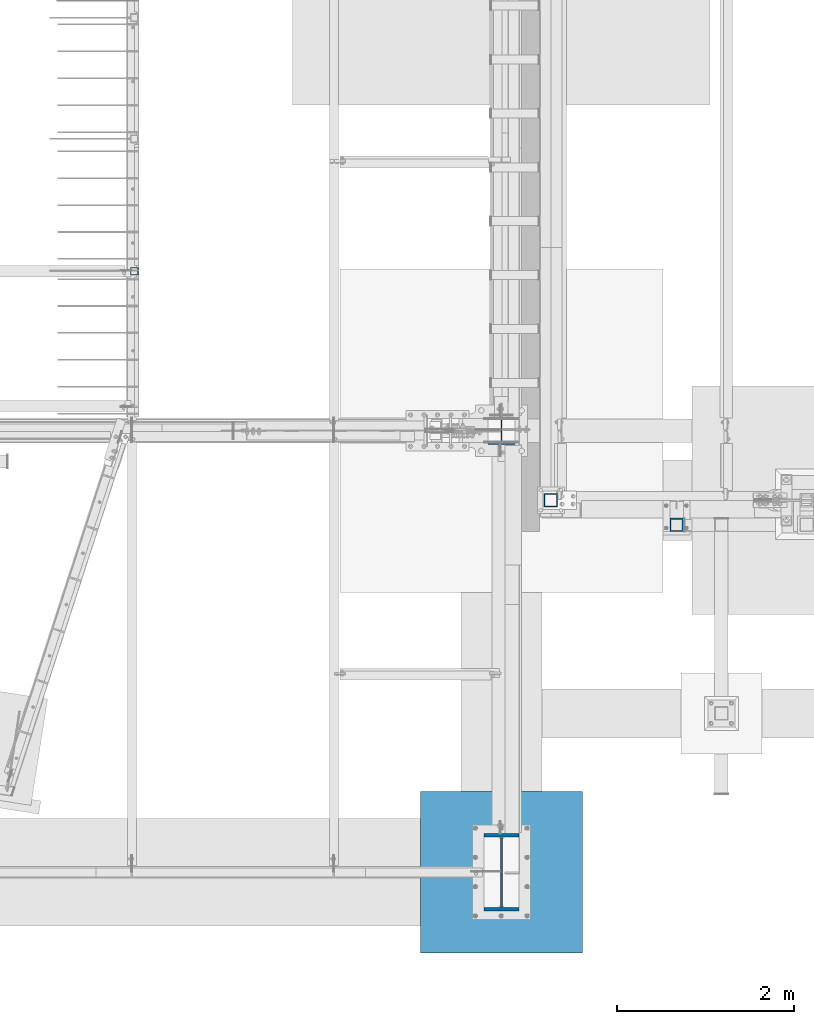
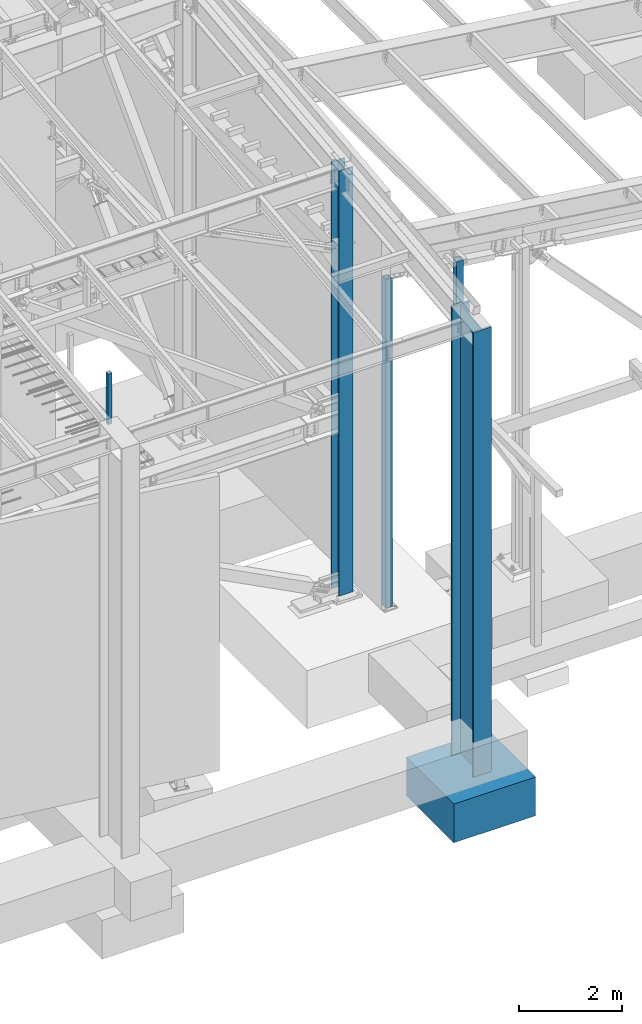
# One storey, part 354 of 1179: 6 columns, 6 elements without a shape of their own.
"""IFC2X3 building model written with IfcOpenShell, lengths in millimetres."""

from ifc_helpers import new_model, si_unit, frame, origin_with_axes, place, context, subcontext, project, spatial, faceted_brep, material, type_object, element, aggregate, save


model = new_model("IFC2X3")

# Units and contexts
model_context = context("Model", 3, precision=1e-05, world=origin_with_axes())
body_context = subcontext(model_context, "Body", "Model", "MODEL_VIEW")
ifc_project = project(units=[si_unit("LENGTHUNIT", "METRE", prefix="MILLI"), si_unit("AREAUNIT", "SQUARE_METRE"), si_unit("VOLUMEUNIT", "CUBIC_METRE"), si_unit("MASSUNIT", "GRAM", prefix="KILO"), si_unit("TIMEUNIT", "SECOND"), si_unit("PLANEANGLEUNIT", "RADIAN"), si_unit("SOLIDANGLEUNIT", "STERADIAN"), si_unit("THERMODYNAMICTEMPERATUREUNIT", "DEGREE_CELSIUS"), si_unit("LUMINOUSINTENSITYUNIT", "LUMEN")], contexts=[model_context])

# Site, building, storey
site_placement = place(None, origin_with_axes())
site = spatial("IfcSite", under=ifc_project, at=site_placement, CompositionType="ELEMENT")
building_placement = place(site_placement, origin_with_axes())
building = spatial("IfcBuilding", under=site, at=building_placement, Name="Undefined", CompositionType="ELEMENT")
storey_placement = place(building_placement, origin_with_axes())
storey = spatial("IfcBuildingStorey", under=building, at=storey_placement, Name="Undefined", CompositionType="ELEMENT", Elevation=0.0)

# Assembly, column
assembly_1_placement = place(storey_placement, origin_with_axes())
assembly_1 = element("IfcElementAssembly", 1, at=assembly_1_placement, inside=storey, Name="COLUMN", AssemblyPlace="NOTDEFINED", PredefinedType="RIGID_FRAME")
ifc_material_1 = material()
column_type_1 = type_object("IfcColumnType", Name="HSS6X6X3/8", PredefinedType="NOTDEFINED")
column_1_placement = place(assembly_1_placement, frame((24866.6, 4648.2, -355.6), z_axis=(0.0, 1.0, 0.0), x_axis=(0.0, 0.0, 1.0)))
column_1 = element("IfcColumn", 2, at=column_1_placement, type_object=column_type_1, material=ifc_material_1, Name="COLUMN", ObjectType="HSS6X6X3/8", context=body_context, shape_type="Brep", body=[
    faceted_brep([(76.2000000000008, 66.675000000112, -66.6749999999902), (76.2000000000008, -66.6750000001084, -66.6750000000175), (7835.60224230485, -66.6749999999993, -66.6750000000002), (7817.5963138271, 66.6749999999993, -66.6750000000002), (76.2000000000008, -66.6750000001011, 66.674999999992), (7835.60224230485, -66.6749999999993, 66.6750000000002), (76.2000000000008, 66.6750000001193, 66.6750000000193), (7817.5963138271, 66.6749999999993, 66.6750000000002), (76.2000000000008, 76.2000000001281, -76.1999999999898), (76.2000000000008, 76.2000000001317, 76.2000000000216), (7816.31017607869, 76.2000000000007, 76.1999999999998), (7816.31017607869, 76.2000000000007, -76.1999999999998), (76.2000000000008, -76.2000000001171, 76.1999999999916), (7836.88838005326, -76.2000000000007, 76.1999999999998), (76.2000000000008, -76.2000000001208, -76.2000000000198), (7836.88838005326, -76.2000000000007, -76.1999999999998)], [[[0, 1, 2, 3]], [[1, 4, 5, 2]], [[4, 6, 7, 5]], [[6, 0, 3, 7]], [[8, 9, 10, 11]], [[9, 12, 13, 10]], [[12, 14, 15, 13]], [[14, 8, 11, 15]], [[13, 15, 11, 10], [5, 7, 3, 2]], [[14, 12, 9, 8], [6, 4, 1, 0]]]),
])
aggregate(assembly_1, [column_1])

assembly_2_placement = place(storey_placement, origin_with_axes())
assembly_2 = element("IfcElementAssembly", 3, at=assembly_2_placement, inside=storey, Name="COLUMN", AssemblyPlace="NOTDEFINED", PredefinedType="RIGID_FRAME")
column_type_2 = type_object("IfcColumnType", Name="HSS3-1/2X3-1/2X5/16", PredefinedType="NOTDEFINED")
column_2_placement = place(assembly_2_placement, frame((20154.9, 7239.0, 4102.1), z_axis=(0.0, 1.0, 0.0), x_axis=(0.0, 0.0, 1.0)))
column_2 = element("IfcColumn", 4, at=column_2_placement, type_object=column_type_2, material=ifc_material_1, Name="COLUMN", ObjectType="HSS3-1/2X3-1/2X5/16", context=body_context, shape_type="Brep", body=[
    faceted_brep([(0.0, 36.5125000000007, -36.5125000000007), (0.0, -36.5125000000007, -36.5125000000007), (1195.387, -36.5125000000007, -36.5125000000007), (1195.387, 36.5125000000007, -36.5125000000007), (0.0, -36.5125000000007, 36.5125000000007), (1195.387, -36.5125000000007, 36.5125000000007), (0.0, 36.5125000000007, 36.5125000000007), (1195.387, 36.5125000000007, 36.5125000000007), (0.0, 44.4500000000007, -44.4499999999998), (0.0, 44.4500000000007, 44.4500000000007), (1195.387, 44.4500000000007, 44.4500000000007), (1195.387, 44.4500000000007, -44.4500000000007), (0.0, -44.4500000000007, 44.4500000000007), (1195.387, -44.4500000000007, 44.4500000000007), (0.0, -44.4500000000007, -44.4500000000007), (1195.387, -44.4500000000007, -44.4500000000007)], [[[0, 1, 2, 3]], [[1, 4, 5, 2]], [[4, 6, 7, 5]], [[6, 0, 3, 7]], [[8, 9, 10, 11]], [[9, 12, 13, 10]], [[12, 14, 15, 13]], [[14, 8, 11, 15]], [[13, 15, 11, 10], [5, 7, 3, 2]], [[14, 12, 9, 8], [6, 4, 1, 0]]]),
])
aggregate(assembly_2, [column_2])

assembly_3_placement = place(storey_placement, origin_with_axes())
assembly_3 = element("IfcElementAssembly", 5, at=assembly_3_placement, inside=storey, Name="FOOTING", AssemblyPlace="NOTDEFINED", PredefinedType="REINFORCEMENT_UNIT")
ifc_material_2 = material(Name="CONCRETE/3000")
column_type_3 = type_object("IfcColumnType", PredefinedType="NOTDEFINED")
column_3_placement = place(assembly_3_placement, frame((24307.8, 438.15, -2260.6), z_axis=(-1.0, 0.0, 0.0), x_axis=(0.0, 0.0, 1.0)))
column_3 = element("IfcColumn", 6, at=column_3_placement, type_object=column_type_3, material=ifc_material_2, Name="FOOTING", context=body_context, shape_type="Brep", body=[
    faceted_brep([(0.0, 914.400000000001, -914.400000000001), (0.0, 914.400000000001, 914.400000000001), (914.4, 914.4, 914.400000000001), (914.4, 914.4, -914.400000000001), (0.0, -914.400000000001, 914.400000000001), (914.4, -914.4, 914.400000000001), (0.0, -914.400000000001, -914.400000000001), (914.4, -914.4, -914.400000000001)], [[[0, 1, 2, 3]], [[1, 4, 5, 2]], [[4, 6, 7, 5]], [[6, 0, 3, 7]], [[5, 7, 3, 2]], [[6, 4, 1, 0]]]),
])
aggregate(assembly_3, [column_3])

assembly_4_placement = place(storey_placement, origin_with_axes())
assembly_4 = element("IfcElementAssembly", 7, at=assembly_4_placement, inside=storey, Name="COLUMN", AssemblyPlace="NOTDEFINED", PredefinedType="RIGID_FRAME")
column_type_4 = type_object("IfcColumnType", Name="HSS6X6X1/2", PredefinedType="NOTDEFINED")
column_4_placement = place(assembly_4_placement, frame((26289.0, 4368.8, -431.8), z_axis=(0.0, 1.0, 0.0), x_axis=(0.0, 0.0, 1.0)))
column_4 = element("IfcColumn", 8, at=column_4_placement, type_object=column_type_4, material=ifc_material_1, Name="COLUMN", ObjectType="HSS6X6X1/2", context=body_context, shape_type="Brep", body=[
    faceted_brep([(57.15, 63.5, -63.5), (57.15, -63.5, -63.5), (7997.7194715117, -63.5, -63.5), (7997.7194715117, 63.5, -63.5), (57.15, -63.5, 63.5), (7997.7194715117, -63.5, 63.5), (57.15, 63.5, 63.5), (7997.7194715117, 63.5, 63.5), (57.15, 76.1999999999789, -76.1999999999953), (57.15, 76.2000000000112, 76.1999999999979), (7997.7194715117, 76.2000000000007, 76.1999999999998), (7997.7194715117, 76.2000000000007, -76.1999999999998), (57.15, -76.1999999999789, 76.1999999999952), (7997.7194715117, -76.2000000000007, 76.1999999999998), (57.15, -76.2000000000116, -76.199999999998), (7997.7194715117, -76.2000000000007, -76.1999999999998)], [[[0, 1, 2, 3]], [[1, 4, 5, 2]], [[4, 6, 7, 5]], [[6, 0, 3, 7]], [[8, 9, 10, 11]], [[9, 12, 13, 10]], [[12, 14, 15, 13]], [[14, 8, 11, 15]], [[13, 15, 11, 10], [5, 7, 3, 2]], [[14, 12, 9, 8], [6, 4, 1, 0]]]),
])
aggregate(assembly_4, [column_4])

assembly_5_placement = place(storey_placement, origin_with_axes())
assembly_5 = element("IfcElementAssembly", 9, at=assembly_5_placement, inside=storey, Name="COLUMN", AssemblyPlace="NOTDEFINED", PredefinedType="RIGID_FRAME")
ifc_material_3 = material(Name="STEEL/A992")
column_type_5 = type_object("IfcColumnType", Name="W33X263", PredefinedType="NOTDEFINED")
column_5_placement = place(assembly_5_placement, frame((24307.8, 438.15, -1346.2), z_axis=(0.0, 1.0, 0.0), x_axis=(0.0, 0.0, 1.0)))
column_5 = element("IfcColumn", 10, at=column_5_placement, type_object=column_type_5, material=ifc_material_3, Name="COLUMN", ObjectType="W33X263", context=body_context, shape_type="Brep", body=[
    faceted_brep([(88.8999999999999, 200.025000000001, -438.15), (88.8999999999999, 200.025000000001, -398.4625), (10587.9886488325, 200.025000000001, -398.4625), (10583.5040139534, 200.025000000001, -438.15), (88.8999999999999, 11.1124999999993, -398.4625), (10587.9886488325, 11.1124999999993, -398.4625), (88.8999999999999, 11.1124999999993, 398.4625), (10678.0401172034, 11.1124999999993, 398.4625), (88.8999999999999, 200.025000000001, 398.4625), (10678.0401172034, 200.025000000001, 398.4625), (88.8999999999999, 200.025000000001, 438.15), (10682.5247520824, 200.025000000001, 438.15), (88.8999999999999, -200.025000000001, 438.15), (10682.5247520824, -200.025000000001, 438.15), (88.8999999999999, -200.025000000001, 398.4625), (10678.0401172034, -200.025000000001, 398.4625), (88.8999999999999, -11.1124999999993, 398.4625), (10678.0401172034, -11.1124999999993, 398.4625), (88.8999999999999, -11.1124999999993, -398.4625), (10587.9886488325, -11.1124999999993, -398.4625), (88.8999999999999, -200.025000000001, -398.4625), (10587.9886488325, -200.025000000001, -398.4625), (88.8999999999999, -200.025000000001, -438.15), (10583.5040139534, -200.025000000001, -438.15)], [[[0, 1, 2, 3]], [[1, 4, 5, 2]], [[4, 6, 7, 5]], [[6, 8, 9, 7]], [[8, 10, 11, 9]], [[10, 12, 13, 11]], [[12, 14, 15, 13]], [[14, 16, 17, 15]], [[16, 18, 19, 17]], [[18, 20, 21, 19]], [[20, 22, 23, 21]], [[22, 0, 3, 23]], [[5, 7, 9, 11, 13, 15, 17, 19, 21, 23, 3, 2]], [[22, 20, 18, 16, 14, 12, 10, 8, 6, 4, 1, 0]]]),
])
aggregate(assembly_5, [column_5])

assembly_6_placement = place(storey_placement, origin_with_axes())
assembly_6 = element("IfcElementAssembly", 11, at=assembly_6_placement, inside=storey, Name="COLUMN", AssemblyPlace="NOTDEFINED", PredefinedType="RIGID_FRAME")
column_type_6 = type_object("IfcColumnType", Name="W12X79", PredefinedType="NOTDEFINED")
column_6_placement = place(assembly_6_placement, frame((24307.8, 5435.6, -355.6), z_axis=(0.0, 1.0, 0.0), x_axis=(0.0, 0.0, 1.0)))
column_6 = element("IfcColumn", 12, at=column_6_placement, type_object=column_type_6, material=ifc_material_3, Name="COLUMN", ObjectType="W12X79", context=body_context, shape_type="Brep", body=[
    faceted_brep([(160.223581529497, -153.987499999999, 157.1625), (160.223581529497, 153.987499999999, 157.1625), (149.225002356772, 153.987499999999, 138.1125), (149.225002356772, 6.35000012494493, 138.1125), (148.995793121516, 6.35000012313685, 137.715499999996), (148.995793121516, -6.34999999999854, 137.715499999996), (149.225002356772, -6.34999999999854, 138.1125), (149.225002356772, -153.987499999999, 138.1125), (10186.1652472574, 153.987499999999, -157.1625), (10186.1652472574, -153.987499999999, -157.1625), (160.223597538519, -153.987499999999, -157.1625), (160.223597538519, 153.987499999999, -157.1625), (10188.3178456909, -153.987499999999, -138.1125), (149.225402461476, -153.987499999999, -138.1125), (10188.3178456909, -6.34999999999854, -138.1125), (149.225402461476, -6.34999999999854, -138.1125), (188.913, -6.34999999999854, 137.715499999996), (188.913, 6.35000008947463, 137.715499999996), (208.49066058208, 6.35000008789211, 131.2871410688), (208.49066058208, -6.34999999999854, 131.2871410688), (212.873373738864, 6.35000008718271, 128.290736246858), (212.873373738864, -6.34999999999854, 128.290736246858), (214.971292158606, 6.35000008606585, 123.413713099926), (214.971292158606, -6.34999999999854, 123.413713099926), (214.132634973196, 6.3500000848835, 118.171264187733), (214.132634973196, -6.34999999999854, 118.171264187733), (210.617956026487, 6.35000008400311, 114.192112472459), (210.617956026487, -6.34999999999854, 114.192112472459), (205.519195059062, 6.35000008370116, 112.712499999996), (205.519195059062, -6.34999999999854, 112.712499999996), (147.032344061553, 6.35000011347802, 112.712499999996), (139.700000000001, -6.34999999999854, 112.712499999996), (147.032344061555, 6.35000001149092, -112.712500000003), (139.700000000001, -6.34999999999854, -112.712500000003), (205.519195059063, 6.3500000365857, -112.712500000003), (205.519195059063, -6.34999999999854, -112.712500000003), (210.617956026486, 6.35000003621826, -114.192112472468), (210.617956026486, -6.34999999999854, -114.192112472468), (214.132634973195, 6.35000003529422, -118.171264187741), (214.132634973195, -6.34999999999854, -118.171264187741), (214.971292158605, 6.35000003410096, -123.413713099934), (214.971292158605, -6.34999999999854, -123.413713099934), (212.873373738863, 6.35000003300956, -128.290736246865), (212.873373738863, -6.34999999999854, -128.290736246865), (208.49066058208, 6.35000003235837, -131.287141068808), (208.49066058208, -6.34999999999854, -131.287141068808), (188.913, 6.35000003102323, -137.715500000003), (188.913, -6.34999999999854, -137.715500000003), (148.99620123074, 6.35000000162472, -137.715500000003), (148.99620123074, -6.34999999999854, -137.715500000003), (10188.3178456909, 6.34999999999854, -138.1125), (10188.3178456909, 153.987499999999, -138.1125), (149.225402461476, 153.987499999999, -138.1125), (149.225402461477, 6.34999999999854, -138.1125), (10219.5305229762, 6.34999999999854, 138.1125), (10219.5305229762, 153.987499999999, 138.1125), (10221.6831214096, 153.987499999999, 157.1625), (10221.6831214096, -153.987499999999, 157.1625), (10219.5305229762, -153.987499999999, 138.1125), (10219.5305229762, -6.34999999999854, 138.1125)], [[[0, 1, 2, 3, 4, 5, 6, 7]], [[8, 9, 10, 11]], [[9, 12, 13, 10]], [[12, 14, 15, 13]], [[16, 17, 18, 19]], [[19, 18, 20, 21]], [[21, 20, 22, 23]], [[23, 22, 24, 25]], [[25, 24, 26, 27]], [[27, 26, 28, 29]], [[29, 28, 30, 31]], [[32, 33, 31, 30]], [[33, 32, 34, 35]], [[35, 34, 36, 37]], [[37, 36, 38, 39]], [[39, 38, 40, 41]], [[41, 40, 42, 43]], [[43, 42, 44, 45]], [[45, 44, 46, 47]], [[47, 46, 48, 49]], [[50, 51, 52, 53]], [[10, 13, 15, 49, 48, 53, 52, 11]], [[51, 8, 11, 52]], [[50, 54, 55, 56, 57, 58, 59, 14, 12, 9, 8, 51]], [[58, 57, 0, 7]], [[59, 58, 7, 6]], [[16, 19, 21, 23, 25, 27, 29, 31, 33, 35, 37, 39, 41, 43, 45, 47, 49, 15, 14, 59, 6, 5]], [[17, 16, 5, 4]], [[54, 50, 53, 48, 46, 44, 42, 40, 38, 36, 34, 32, 30, 28, 26, 24, 22, 20, 18, 17, 4, 3]], [[55, 54, 3, 2]], [[56, 55, 2, 1]], [[57, 56, 1, 0]]]),
])
aggregate(assembly_6, [column_6])

save(model, "model.ifc")
